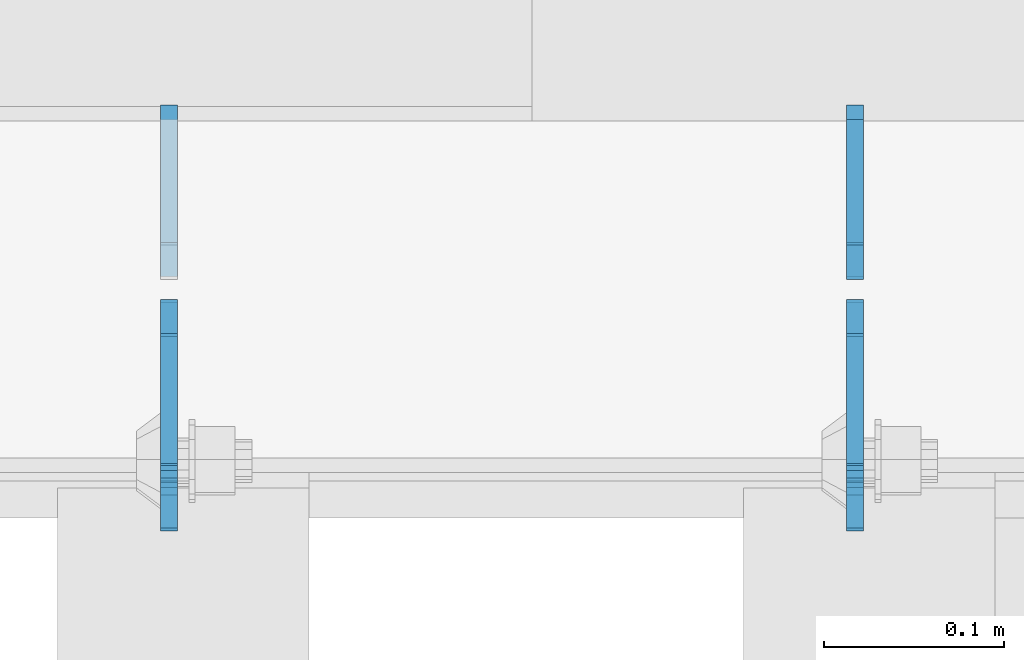
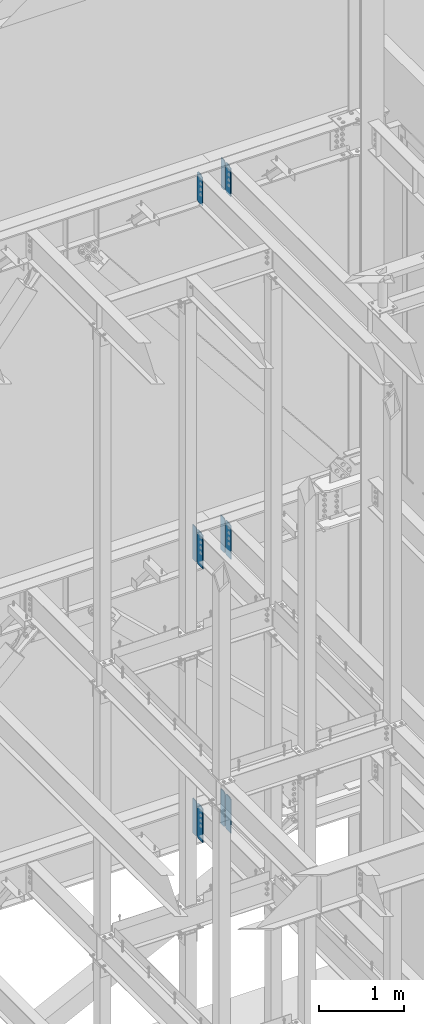
# One storey, part 1102 of 1179: 11 plates, 3 elements without a shape of their own.
"""IFC2X3 building model written with IfcOpenShell, lengths in millimetres."""

import ifcopenshell
import ifcopenshell.guid

model = None  # the IFC model being written
_history = None  # IfcOwnerHistory: only IFC2X3 demands one
_inside = {}  # id of a spatial element -> (the spatial element, [elements in it])
_under = {}  # id of a project, library or spatial element -> (it, [spatial elements below it])
_declared = {}  # id of a project -> (the project, [libraries it declares])
_typed = {}  # id of a type object -> (the type object, [elements of that type])
_made_of = {}  # id of a material, layer set ... -> (it, [elements and type objects made of it])


def new_model(schema):
    """Start an empty IFC model of exactly this schema.

    Asked for "IFC4X3", IfcOpenShell would pick the latest addendum, in which some entities
    have other attributes; the version numbers below select the first issue.
    IFC2X3 requires an IfcOwnerHistory on every rooted entity: one is made here for all.
    """
    global model, _history
    if schema == "IFC4X3":
        model = ifcopenshell.file(schema_version=(4, 3, 0, 0))
    else:
        model = ifcopenshell.file(schema=schema)
    _inside.clear()
    _under.clear()
    _declared.clear()
    _typed.clear()
    _made_of.clear()
    _history = None
    if model.schema == "IFC2X3":
        org = make("IfcOrganization", Name="unknown")
        user = make(
            "IfcPersonAndOrganization",
            ThePerson=make("IfcPerson", FamilyName="unknown"),
            TheOrganization=org,
        )
        app = make(
            "IfcApplication",
            ApplicationDeveloper=org,
            Version="unknown",
            ApplicationFullName="unknown",
            ApplicationIdentifier="unknown",
        )
        _history = make(
            "IfcOwnerHistory",
            OwningUser=user,
            OwningApplication=app,
            ChangeAction="ADDED",
            CreationDate=0,
        )
    return model


def make(cls, **values):
    """One entity of the class cls with the attributes given. An attribute that is None is left unset."""
    return model.create_entity(
        cls, **{name: value for name, value in values.items() if value is not None}
    )


def rooted(cls, **values):
    """An entity with a GlobalId (a new one), such as an element, a storey or a relation."""
    return make(cls, GlobalId=ifcopenshell.guid.new(), OwnerHistory=_history, **values)


def si_unit(unit_type, name, prefix=None):
    """IfcSIUnit, for example si_unit("LENGTHUNIT", "METRE", prefix="MILLI")."""
    return make("IfcSIUnit", UnitType=unit_type, Prefix=prefix, Name=name)


def assignment(units):
    """IfcUnitAssignment: the units of a project."""
    return None if units is None else make("IfcUnitAssignment", Units=units)


def point(xyz):
    """IfcCartesianPoint."""
    return None if xyz is None else make("IfcCartesianPoint", Coordinates=xyz)


def direction(xyz):
    """IfcDirection."""
    return None if xyz is None else make("IfcDirection", DirectionRatios=xyz)


def frame(location, z_axis=None, x_axis=None):
    """IfcAxis2Placement3D, a coordinate frame: its origin and axes. An axis left out is left unset."""
    return make(
        "IfcAxis2Placement3D",
        Location=point(location),
        Axis=direction(z_axis),
        RefDirection=direction(x_axis),
    )


def origin_with_axes():
    """The frame at (0, 0, 0) with the z axis (0, 0, 1) and the x axis (1, 0, 0) written out."""
    return frame((0.0, 0.0, 0.0), z_axis=(0.0, 0.0, 1.0), x_axis=(1.0, 0.0, 0.0))


def place(relative_to, where):
    """IfcLocalPlacement: puts the frame where relative to a parent placement (None: the world)."""
    return make(
        "IfcLocalPlacement", PlacementRelTo=relative_to, RelativePlacement=where
    )


def context(
    kind, dimensions, precision=None, world=None, true_north=None, identifier=None
):
    """IfcGeometricRepresentationContext, for example the 3D "Model" context."""
    return make(
        "IfcGeometricRepresentationContext",
        ContextIdentifier=identifier,
        ContextType=kind,
        CoordinateSpaceDimension=dimensions,
        Precision=precision,
        WorldCoordinateSystem=world,
        TrueNorth=true_north,
    )


def subcontext(parent, identifier, kind, view, scale=None):
    """IfcGeometricRepresentationSubContext, for example "Body" below "Model"."""
    return make(
        "IfcGeometricRepresentationSubContext",
        ContextIdentifier=identifier,
        ContextType=kind,
        ParentContext=parent,
        TargetScale=scale,
        TargetView=view,
    )


def project(units=None, contexts=None):
    """IfcProject with its units and contexts."""
    return rooted(
        "IfcProject",
        Name="project",
        RepresentationContexts=contexts,
        UnitsInContext=assignment(units),
    )


def spatial(cls, under=None, at=None, **own):
    """A site, building, storey or space (cls), placed at a placement, below another one or the project."""
    s = rooted(cls, ObjectPlacement=at, **own)
    if under is not None:
        _under.setdefault(under.id(), (under, []))[1].append(s)
    return s


def faces_of(points, faces, orient=None, outer=None):
    """IfcFace entities. A face is a list of loops; a loop is a list of indices into points, from 0.

    orient and outer hold one flag for each loop. By default every Orientation is true, the
    first loop of a face is its IfcFaceOuterBound and the others are IfcFaceBound.
    """
    made = []
    for i, loops in enumerate(faces):
        bounds = []
        for j, loop in enumerate(loops):
            is_outer = j == 0 if outer is None else outer[i][j]
            bounds.append(
                make(
                    "IfcFaceOuterBound" if is_outer else "IfcFaceBound",
                    Bound=make("IfcPolyLoop", Polygon=[points[k] for k in loop]),
                    Orientation=True if orient is None else orient[i][j],
                )
            )
        made.append(make("IfcFace", Bounds=bounds))
    return made


def faceted_brep(points, faces, orient=None, outer=None, voids=None):
    """IfcFacetedBrep: a solid bounded by flat faces; with voids (closed shells), ...WithVoids."""
    shared = [point(p) for p in points]
    hull = make("IfcClosedShell", CfsFaces=faces_of(shared, faces, orient, outer))
    if voids is None:
        return make("IfcFacetedBrep", Outer=hull)
    return make(
        "IfcFacetedBrepWithVoids",
        Outer=hull,
        Voids=[
            make(cls, CfsFaces=faces_of(shared, fs, o, b)) for cls, fs, o, b in voids
        ],
    )


def shape(context_of_items, identifier, shape_type, items):
    """IfcShapeRepresentation: the items that make up one representation, for example the "Body"."""
    return make(
        "IfcShapeRepresentation",
        ContextOfItems=context_of_items,
        RepresentationIdentifier=identifier,
        RepresentationType=shape_type,
        Items=items,
    )


def material(Name=None, Category=None):
    """IfcMaterial."""
    return make("IfcMaterial", Name=Name, Category=Category)


def made_of(thing, what):
    """Note that an element or type object is made of a material, layer set ...; save() writes the relation."""
    if what is not None:
        _made_of.setdefault(what.id(), (what, []))[1].append(thing)
    return thing


def type_object(cls, material=None, **own):
    """A type object (cls), such as IfcWallType, which elements share."""
    return made_of(rooted(cls, **own), material)


def element(
    cls,
    number,
    at=None,
    inside=None,
    cuts=None,
    type_object=None,
    material=None,
    context=None,
    identifier="Body",
    shape_type=None,
    held_by="IfcProductDefinitionShape",
    body=None,
    shapes=None,
    **own,
):
    """One element of the class cls, such as IfcWall. Its Tag is "e" and its number.

    at: its placement. inside: the storey or other place that contains it. cuts: it is an
    opening in that element (IfcRelVoidsElement). A single representation is given by context,
    identifier, shape_type and body (its items); several are given by shapes. held_by: the class
    of the entity that holds the representations. save() writes the other relations.
    """
    e = rooted(cls, Tag="e%d" % number, ObjectPlacement=at, **own)
    if body is not None:
        shapes = [shape(context, identifier, shape_type, body)]
    if shapes is not None:
        e.Representation = make(held_by, Representations=shapes)
    if inside is not None:
        _inside.setdefault(inside.id(), (inside, []))[1].append(e)
    if cuts is not None:
        rooted(
            "IfcRelVoidsElement", RelatingBuildingElement=cuts, RelatedOpeningElement=e
        )
    if type_object is not None:
        _typed.setdefault(type_object.id(), (type_object, []))[1].append(e)
    return made_of(e, material)


def aggregate(whole, parts):
    """IfcRelAggregates: a whole, such as a stair, and the parts it consists of."""
    return rooted("IfcRelAggregates", RelatingObject=whole, RelatedObjects=parts)


def save(model, path):
    """Write the relations noted so far, then the file.

    IfcRelAggregates (storeys below a building ...), IfcRelContainedInSpatialStructure (elements
    in a storey), IfcRelDefinesByType, IfcRelAssociatesMaterial and IfcRelDeclares: one each for
    every whole, place, type object, material and project.
    """
    for whole, parts in _under.values():
        aggregate(whole, parts)
    for where, things in _inside.values():
        rooted(
            "IfcRelContainedInSpatialStructure",
            RelatedElements=things,
            RelatingStructure=where,
        )
    for kind, things in _typed.values():
        rooted("IfcRelDefinesByType", RelatedObjects=things, RelatingType=kind)
    for what, things in _made_of.values():
        rooted("IfcRelAssociatesMaterial", RelatedObjects=things, RelatingMaterial=what)
    for by, libraries in _declared.values():
        rooted("IfcRelDeclares", RelatingContext=by, RelatedDefinitions=libraries)
    model.write(path)


model = new_model("IFC2X3")

# Units and contexts
model_context = context("Model", 3, precision=1e-05, world=origin_with_axes())
body_context = subcontext(model_context, "Body", "Model", "MODEL_VIEW")
ifc_project = project(units=[si_unit("LENGTHUNIT", "METRE", prefix="MILLI"), si_unit("AREAUNIT", "SQUARE_METRE"), si_unit("VOLUMEUNIT", "CUBIC_METRE"), si_unit("MASSUNIT", "GRAM", prefix="KILO"), si_unit("TIMEUNIT", "SECOND"), si_unit("PLANEANGLEUNIT", "RADIAN"), si_unit("SOLIDANGLEUNIT", "STERADIAN"), si_unit("THERMODYNAMICTEMPERATUREUNIT", "DEGREE_CELSIUS"), si_unit("LUMINOUSINTENSITYUNIT", "LUMEN")], contexts=[model_context])

# Site, building, storey
site_placement = place(None, origin_with_axes())
site = spatial("IfcSite", under=ifc_project, at=site_placement, CompositionType="ELEMENT")
building_placement = place(site_placement, origin_with_axes())
building = spatial("IfcBuilding", under=site, at=building_placement, Name="Undefined", CompositionType="ELEMENT")
storey_placement = place(building_placement, origin_with_axes())
storey = spatial("IfcBuildingStorey", under=building, at=storey_placement, Name="Undefined", CompositionType="ELEMENT", Elevation=0.0)

# Assembly, plates
assembly_1_placement = place(storey_placement, origin_with_axes())
assembly_1 = element("IfcElementAssembly", 1, at=assembly_1_placement, inside=storey, Name="BEAM", AssemblyPlace="NOTDEFINED", PredefinedType="RIGID_FRAME")
ifc_material = material(Name="STEEL/A36")
plate_type_1 = type_object("IfcPlateType", PredefinedType="NOTDEFINED")
plate_1_placement = place(assembly_1_placement, frame((14177.9620000839, 41193.24375, 12673.0125), z_axis=(0.0, 0.0, 1.0), x_axis=(0.0, -1.0, 0.0)))
plate_1 = element("IfcPlate", 2, at=plate_1_placement, type_object=plate_type_1, material=ifc_material, Name="PLATE", context=body_context, shape_type="Brep", body=[
    faceted_brep([(91.28125, -4.76250000000073, 425.450000000001), (91.28125, -4.76250000000073, 420.687499809264), (91.28125, 4.76250000000073, 420.687499809264), (91.28125, 4.76250000000073, 425.450000000001), (92.2479799225912, -4.76250000000073, 415.827420291219), (92.2479799225912, 4.76250000000073, 415.827420291219), (95.0009938230651, -4.76250000000073, 411.707243823065), (95.0009938230651, 4.76250000000073, 411.707243823065), (99.1211702912187, -4.76250000000073, 408.954229922587), (99.1211702912187, 4.76250000000073, 408.954229922587), (103.981249809265, -4.76250000000073, 407.987499999999), (103.981249809265, 4.76250000000073, 407.987499999999), (126.999999992826, -4.76249999999709, 407.9875), (127.0, 4.76249999999709, 407.9875), (0.0, -4.76249999999709, 406.400000762939), (19.0499992370605, -4.76249999999709, 425.45), (19.0499992370605, 4.76249999999709, 425.45), (0.0, 4.76249999999709, 406.400000762939), (0.0, -4.76250000000073, 19.0499992370605), (0.0, 4.76250000000073, 19.0499992370605), (19.0499992370605, -4.76250000000073, 0.0), (19.0499992370605, 4.76250000000073, 0.0), (127.0, -4.76250000000073, 0.0), (127.0, 4.76250000000073, 0.0)], [[[0, 1, 2, 3]], [[4, 5, 2, 1]], [[6, 7, 5, 4]], [[8, 9, 7, 6]], [[10, 11, 9, 8]], [[12, 13, 11, 10]], [[14, 15, 16, 17]], [[18, 14, 17, 19]], [[20, 18, 19, 21]], [[22, 20, 21, 23]], [[8, 6, 4, 1, 0, 15, 14, 18, 20, 22, 12, 10]], [[16, 15, 0, 3]], [[23, 21, 19, 17, 16, 3, 2, 5, 7, 9, 11, 13]], [[22, 23, 13, 12]]]),
])
plate_2_placement = place(assembly_1_placement, frame((14558.9620000839, 41193.24375, 12673.0125), z_axis=(0.0, 0.0, 1.0), x_axis=(0.0, -1.0, 0.0)))
plate_2 = element("IfcPlate", 3, at=plate_2_placement, type_object=plate_type_1, material=ifc_material, Name="PLATE", context=body_context, shape_type="Brep", body=[
    faceted_brep([(91.28125, -4.76250000000073, 425.450000000001), (91.28125, -4.76250000000073, 420.687499809264), (91.28125, 4.76250000000073, 420.687499809264), (91.28125, 4.76250000000073, 425.450000000001), (92.2479799225912, -4.76250000000073, 415.827420291219), (92.2479799225912, 4.76250000000073, 415.827420291219), (95.0009938230651, -4.76250000000073, 411.707243823065), (95.0009938230651, 4.76250000000073, 411.707243823065), (99.1211702912187, -4.76250000000073, 408.954229922587), (99.1211702912187, 4.76250000000073, 408.954229922587), (103.981249809265, -4.76250000000073, 407.987499999999), (103.981249809265, 4.76250000000073, 407.987499999999), (126.999999992826, -4.76249999999709, 407.9875), (127.0, 4.76249999999709, 407.9875), (0.0, -4.76249999999709, 406.400000762939), (19.0499992370605, -4.76249999999709, 425.45), (19.0499992370605, 4.76249999999709, 425.45), (0.0, 4.76249999999709, 406.400000762939), (0.0, -4.76250000000073, 19.0499992370605), (0.0, 4.76250000000073, 19.0499992370605), (19.0499992370605, -4.76250000000073, 0.0), (19.0499992370605, 4.76250000000073, 0.0), (127.0, -4.76250000000073, 0.0), (127.0, 4.76250000000073, 0.0)], [[[0, 1, 2, 3]], [[4, 5, 2, 1]], [[6, 7, 5, 4]], [[8, 9, 7, 6]], [[10, 11, 9, 8]], [[12, 13, 11, 10]], [[14, 15, 16, 17]], [[18, 14, 17, 19]], [[20, 18, 19, 21]], [[22, 20, 21, 23]], [[8, 6, 4, 1, 0, 15, 14, 18, 20, 22, 12, 10]], [[16, 15, 0, 3]], [[23, 21, 19, 17, 16, 3, 2, 5, 7, 9, 11, 13]], [[22, 23, 13, 12]]]),
])

assembly_2_placement = place(storey_placement, origin_with_axes())
assembly_2 = element("IfcElementAssembly", 4, at=assembly_2_placement, inside=storey, Name="BEAM", AssemblyPlace="NOTDEFINED", PredefinedType="RIGID_FRAME")
plate_3_placement = place(assembly_2_placement, frame((14177.9620000839, 41191.65625, 7489.825), z_axis=(0.0, 0.0, 1.0), x_axis=(0.0, -1.0, 0.0)))
plate_3 = element("IfcPlate", 5, at=plate_3_placement, type_object=plate_type_1, material=ifc_material, Name="PLATE", context=body_context, shape_type="Brep", body=[
    faceted_brep([(99.2187497618652, -4.76249999998072, 498.475), (99.21875, -4.76250000000073, 492.124999809264), (99.21875, 4.76250000000073, 492.124999809264), (99.2187499999927, 4.76250000001892, 498.475), (100.185479922588, -4.76250000000073, 487.264920291219), (100.185479922588, 4.76250000000073, 487.264920291219), (102.938493823065, -4.76250000000073, 483.144743823065), (102.938493823065, 4.76250000000073, 483.144743823065), (107.058670291219, -4.76250000000073, 480.391729922587), (107.058670291219, 4.76250000000073, 480.391729922587), (111.918749809265, -4.76250000000073, 479.424999999999), (111.918749809265, 4.76250000000073, 479.424999999999), (127.000007629395, -4.76250000000073, 479.424999999999), (127.000004683803, 4.76250000000073, 479.424999999999), (0.0, -4.76250000000073, 479.425006866455), (19.0499992370605, -4.76250000000073, 498.475006103516), (19.0499992370605, 4.76250000000073, 498.475006103516), (0.0, 4.76250000000073, 479.425006866455), (0.0, -4.76250000000073, 19.0499992370605), (0.0, 4.76250000000073, 19.0499992370605), (19.0499992370605, -4.76250000000073, 0.0), (19.0499992370605, 4.76250000000073, 0.0), (127.0, -4.76250000000073, 0.0), (127.0, 4.76250000000073, 0.0)], [[[0, 1, 2, 3]], [[4, 5, 2, 1]], [[6, 7, 5, 4]], [[8, 9, 7, 6]], [[10, 11, 9, 8]], [[12, 13, 11, 10]], [[14, 15, 16, 17]], [[18, 14, 17, 19]], [[20, 18, 19, 21]], [[22, 20, 21, 23]], [[8, 6, 4, 1, 0, 15, 14, 18, 20, 22, 12, 10]], [[16, 15, 0, 3]], [[23, 21, 19, 17, 16, 3, 2, 5, 7, 9, 11, 13]], [[22, 23, 13, 12]]]),
])
plate_4_placement = place(assembly_2_placement, frame((14558.9620000839, 41191.65625, 7489.825), z_axis=(0.0, 0.0, 1.0), x_axis=(0.0, -1.0, 0.0)))
plate_4 = element("IfcPlate", 6, at=plate_4_placement, type_object=plate_type_1, material=ifc_material, Name="PLATE", context=body_context, shape_type="Brep", body=[
    faceted_brep([(99.2187497618652, -4.76249999998072, 498.475), (99.21875, -4.76250000000073, 492.124999809264), (99.21875, 4.76250000000073, 492.124999809264), (99.2187499999927, 4.76250000001892, 498.475), (100.185479922588, -4.76250000000073, 487.264920291219), (100.185479922588, 4.76250000000073, 487.264920291219), (102.938493823065, -4.76250000000073, 483.144743823065), (102.938493823065, 4.76250000000073, 483.144743823065), (107.058670291219, -4.76250000000073, 480.391729922587), (107.058670291219, 4.76250000000073, 480.391729922587), (111.918749809265, -4.76250000000073, 479.424999999999), (111.918749809265, 4.76250000000073, 479.424999999999), (127.000007629395, -4.76250000000073, 479.424999999999), (127.000004683803, 4.76250000000073, 479.424999999999), (0.0, -4.76250000000073, 479.425006866455), (19.0499992370605, -4.76250000000073, 498.475006103516), (19.0499992370605, 4.76250000000073, 498.475006103516), (0.0, 4.76250000000073, 479.425006866455), (0.0, -4.76250000000073, 19.0499992370605), (0.0, 4.76250000000073, 19.0499992370605), (19.0499992370605, -4.76250000000073, 0.0), (19.0499992370605, 4.76250000000073, 0.0), (127.0, -4.76250000000073, 0.0), (127.0, 4.76250000000073, 0.0)], [[[0, 1, 2, 3]], [[4, 5, 2, 1]], [[6, 7, 5, 4]], [[8, 9, 7, 6]], [[10, 11, 9, 8]], [[12, 13, 11, 10]], [[14, 15, 16, 17]], [[18, 14, 17, 19]], [[20, 18, 19, 21]], [[22, 20, 21, 23]], [[8, 6, 4, 1, 0, 15, 14, 18, 20, 22, 12, 10]], [[16, 15, 0, 3]], [[23, 21, 19, 17, 16, 3, 2, 5, 7, 9, 11, 13]], [[22, 23, 13, 12]]]),
])

assembly_3_placement = place(storey_placement, origin_with_axes())
assembly_3 = element("IfcElementAssembly", 7, at=assembly_3_placement, inside=storey, Name="BEAM", AssemblyPlace="NOTDEFINED", PredefinedType="RIGID_FRAME")
plate_5_placement = place(assembly_3_placement, frame((14558.9620836029, 41191.6562498809, 3578.225), z_axis=(0.0, 0.0, 1.0), x_axis=(0.0, -1.0, 0.0)))
plate_5 = element("IfcPlate", 8, at=plate_5_placement, type_object=plate_type_1, material=ifc_material, Name="PLATE", context=body_context, shape_type="Brep", body=[
    faceted_brep([(100.185729626639, -4.76249977056068, 493.614920291231), (100.185729712364, 4.76250000001892, 493.614920291231), (99.2189997897731, 4.76250000002074, 498.475), (99.218999704055, -4.76249999998072, 498.475), (102.93874352712, -4.76249979533713, 489.494743823075), (102.938743612845, 4.76250000002074, 489.494743823075), (107.058919995281, -4.76249983241905, 486.741729922598), (107.058920081006, 4.76250000002074, 486.741729922598), (111.918999513335, -4.76249987616211, 485.775000000015), (111.918999599053, 4.76250000002074, 485.775000000015), (127.000004753965, -4.76249999997526, 485.775), (127.000004873044, 4.76250000002437, 485.775), (0.0, -4.76250000000073, 479.425006866455), (19.0499992370605, -4.76250000000073, 498.475006103516), (19.0499992370605, 4.76250000000073, 498.475006103516), (0.0, 4.76250000000073, 479.425006866455), (0.0, -4.76250000000073, 19.0499992370605), (0.0, 4.76250000000073, 19.0499992370605), (19.0499992370605, -4.76250000000073, 0.0), (19.0499992370605, 4.76250000000073, 0.0), (127.0, -4.76250000000073, 0.0), (127.0, 4.76250000000073, 0.0)], [[[0, 1, 2, 3]], [[4, 5, 1, 0]], [[6, 7, 5, 4]], [[8, 9, 7, 6]], [[10, 11, 9, 8]], [[12, 13, 14, 15]], [[16, 12, 15, 17]], [[18, 16, 17, 19]], [[20, 18, 19, 21]], [[6, 4, 0, 3, 13, 12, 16, 18, 20, 10, 8]], [[14, 13, 3, 2]], [[21, 19, 17, 15, 14, 2, 1, 5, 7, 9, 11]], [[20, 21, 11, 10]]]),
])
plate_6_placement = place(assembly_3_placement, frame((14177.9619473748, 41191.6562498809, 3578.225), z_axis=(0.0, 0.0, 1.0), x_axis=(0.0, -1.0, 0.0)))
plate_6 = element("IfcPlate", 9, at=plate_6_placement, type_object=plate_type_1, material=ifc_material, Name="PLATE", context=body_context, shape_type="Brep", body=[
    faceted_brep([(100.185729626639, -4.76249977056068, 493.614920291231), (100.185729712364, 4.76250000001892, 493.614920291231), (99.2189997897731, 4.76250000002074, 498.475), (99.218999704055, -4.76249999998072, 498.475), (102.93874352712, -4.76249979533713, 489.494743823075), (102.938743612845, 4.76250000002074, 489.494743823075), (107.058919995281, -4.76249983241905, 486.741729922598), (107.058920081006, 4.76250000002074, 486.741729922598), (111.918999513335, -4.76249987616211, 485.775000000015), (111.918999599053, 4.76250000002074, 485.775000000015), (127.000004753965, -4.76249999997526, 485.775), (127.000004873044, 4.76250000002437, 485.775), (0.0, -4.76250000000073, 479.425006866455), (19.0499992370605, -4.76250000000073, 498.475006103516), (19.0499992370605, 4.76250000000073, 498.475006103516), (0.0, 4.76250000000073, 479.425006866455), (0.0, -4.76250000000073, 19.0499992370605), (0.0, 4.76250000000073, 19.0499992370605), (19.0499992370605, -4.76250000000073, 0.0), (19.0499992370605, 4.76250000000073, 0.0), (127.0, -4.76250000000073, 0.0), (127.0, 4.76250000000073, 0.0)], [[[0, 1, 2, 3]], [[4, 5, 1, 0]], [[6, 7, 5, 4]], [[8, 9, 7, 6]], [[10, 11, 9, 8]], [[12, 13, 14, 15]], [[16, 12, 15, 17]], [[18, 16, 17, 19]], [[20, 18, 19, 21]], [[6, 4, 0, 3, 13, 12, 16, 18, 20, 10, 8]], [[14, 13, 3, 2]], [[21, 19, 17, 15, 14, 2, 1, 5, 7, 9, 11]], [[20, 21, 11, 10]]]),
])

# Plate
plate_type_2 = type_object("IfcPlateType", PredefinedType="NOTDEFINED")
plate_7_placement = place(assembly_1_placement, frame((14558.9620000839, 41204.35625, 12673.0125), z_axis=(0.0, 0.0, 1.0), x_axis=(0.0, 1.0, 0.0)))
plate_7 = element("IfcPlate", 10, at=plate_7_placement, type_object=plate_type_2, material=ifc_material, Name="PLATE", context=body_context, shape_type="Brep", body=[
    faceted_brep([(0.0, -4.76250000000073, 19.0499992370605), (0.0, -4.76249999999709, 406.400000762939), (0.0, 4.76249999999709, 406.400000762939), (0.0, 4.76250000000073, 19.0499992370605), (19.0499992370605, -4.76249999999709, 425.45), (19.0499992370605, 4.76249999999709, 425.45), (88.9000015258789, -4.76250000000073, 425.450012207031), (88.9000015258789, 4.76250000000073, 425.450012207031), (88.8999999999996, -4.76250000000005, 0.0), (88.8999999999996, 4.76250000000005, 0.0), (19.0499992370605, -4.76250000000073, 0.0), (19.0499992370605, 4.76250000000073, 0.0)], [[[0, 1, 2, 3]], [[1, 4, 5, 2]], [[4, 6, 7, 5]], [[6, 8, 9, 7]], [[8, 10, 11, 9]], [[10, 0, 3, 11]], [[5, 7, 9, 11, 3, 2]], [[10, 8, 6, 4, 1, 0]]]),
])

aggregate(assembly_1, [plate_1, plate_7, plate_2])

plate_type_3 = type_object("IfcPlateType", PredefinedType="NOTDEFINED")
plate_8_placement = place(assembly_2_placement, frame((14177.9620000839, 41205.94375, 7489.825), z_axis=(0.0, 0.0, 1.0), x_axis=(0.0, 1.0, 0.0)))
plate_8 = element("IfcPlate", 11, at=plate_8_placement, type_object=plate_type_3, material=ifc_material, Name="PLATE", context=body_context, shape_type="Brep", body=[
    faceted_brep([(0.0, -4.76250000000073, 19.0499992370605), (0.0, -4.76250000000073, 479.425006866455), (0.0, 4.76250000000073, 479.425006866455), (0.0, 4.76250000000073, 19.0499992370605), (19.0499992370605, -4.76250000000073, 498.475006103516), (19.0499992370605, 4.76250000000073, 498.475006103516), (95.25, -4.76250000000073, 498.475006103516), (95.25, 4.76250000000073, 498.475006103516), (95.25, -4.76250000000073, 0.0), (95.25, 4.76250000000073, 0.0), (19.0499992370605, -4.76250000000073, 0.0), (19.0499992370605, 4.76250000000073, 0.0)], [[[0, 1, 2, 3]], [[1, 4, 5, 2]], [[4, 6, 7, 5]], [[6, 8, 9, 7]], [[8, 10, 11, 9]], [[10, 0, 3, 11]], [[5, 7, 9, 11, 3, 2]], [[10, 8, 6, 4, 1, 0]]]),
])

plate_9_placement = place(assembly_2_placement, frame((14558.9620000839, 41205.94375, 7489.825), z_axis=(0.0, 0.0, 1.0), x_axis=(0.0, 1.0, 0.0)))
plate_9 = element("IfcPlate", 12, at=plate_9_placement, type_object=plate_type_3, material=ifc_material, Name="PLATE", context=body_context, shape_type="Brep", body=[
    faceted_brep([(0.0, -4.76250000000073, 19.0499992370605), (0.0, -4.76250000000073, 479.425006866455), (0.0, 4.76250000000073, 479.425006866455), (0.0, 4.76250000000073, 19.0499992370605), (19.0499992370605, -4.76250000000073, 498.475006103516), (19.0499992370605, 4.76250000000073, 498.475006103516), (95.25, -4.76250000000073, 498.475006103516), (95.25, 4.76250000000073, 498.475006103516), (95.25, -4.76250000000073, 0.0), (95.25, 4.76250000000073, 0.0), (19.0499992370605, -4.76250000000073, 0.0), (19.0499992370605, 4.76250000000073, 0.0)], [[[0, 1, 2, 3]], [[1, 4, 5, 2]], [[4, 6, 7, 5]], [[6, 8, 9, 7]], [[8, 10, 11, 9]], [[10, 0, 3, 11]], [[5, 7, 9, 11, 3, 2]], [[10, 8, 6, 4, 1, 0]]]),
])

aggregate(assembly_2, [plate_8, plate_3, plate_9, plate_4])

plate_10_placement = place(assembly_3_placement, frame((14558.9620835822, 41205.94375, 3578.225), z_axis=(0.0, 0.0, 1.0), x_axis=(0.0, 1.0, 0.0)))
plate_10 = element("IfcPlate", 13, at=plate_10_placement, type_object=plate_type_3, material=ifc_material, Name="PLATE", context=body_context, shape_type="Brep", body=[
    faceted_brep([(0.0, -4.76250000000073, 19.0499992370605), (0.0, -4.76250000000073, 479.425006866455), (0.0, 4.76250000000073, 479.425006866455), (0.0, 4.76250000000073, 19.0499992370605), (19.0499992370605, -4.76250000000073, 498.475006103516), (19.0499992370605, 4.76250000000073, 498.475006103516), (95.25, -4.76250000000073, 498.475006103516), (95.25, 4.76250000000073, 498.475006103516), (95.25, -4.76250000000073, 0.0), (95.25, 4.76250000000073, 0.0), (19.0499992370605, -4.76250000000073, 0.0), (19.0499992370605, 4.76250000000073, 0.0)], [[[0, 1, 2, 3]], [[1, 4, 5, 2]], [[4, 6, 7, 5]], [[6, 8, 9, 7]], [[8, 10, 11, 9]], [[10, 0, 3, 11]], [[5, 7, 9, 11, 3, 2]], [[10, 8, 6, 4, 1, 0]]]),
])

plate_11_placement = place(assembly_3_placement, frame((14177.9619473541, 41205.94375, 3578.225), z_axis=(0.0, 0.0, 1.0), x_axis=(0.0, 1.0, 0.0)))
plate_11 = element("IfcPlate", 14, at=plate_11_placement, type_object=plate_type_3, material=ifc_material, Name="PLATE", context=body_context, shape_type="Brep", body=[
    faceted_brep([(0.0, -4.76250000000073, 19.0499992370605), (0.0, -4.76250000000073, 479.425006866455), (0.0, 4.76250000000073, 479.425006866455), (0.0, 4.76250000000073, 19.0499992370605), (19.0499992370605, -4.76250000000073, 498.475006103516), (19.0499992370605, 4.76250000000073, 498.475006103516), (95.25, -4.76250000000073, 498.475006103516), (95.25, 4.76250000000073, 498.475006103516), (95.25, -4.76250000000073, 0.0), (95.25, 4.76250000000073, 0.0), (19.0499992370605, -4.76250000000073, 0.0), (19.0499992370605, 4.76250000000073, 0.0)], [[[0, 1, 2, 3]], [[1, 4, 5, 2]], [[4, 6, 7, 5]], [[6, 8, 9, 7]], [[8, 10, 11, 9]], [[10, 0, 3, 11]], [[5, 7, 9, 11, 3, 2]], [[10, 8, 6, 4, 1, 0]]]),
])

aggregate(assembly_3, [plate_10, plate_5, plate_11, plate_6])

save(model, "model.ifc")
